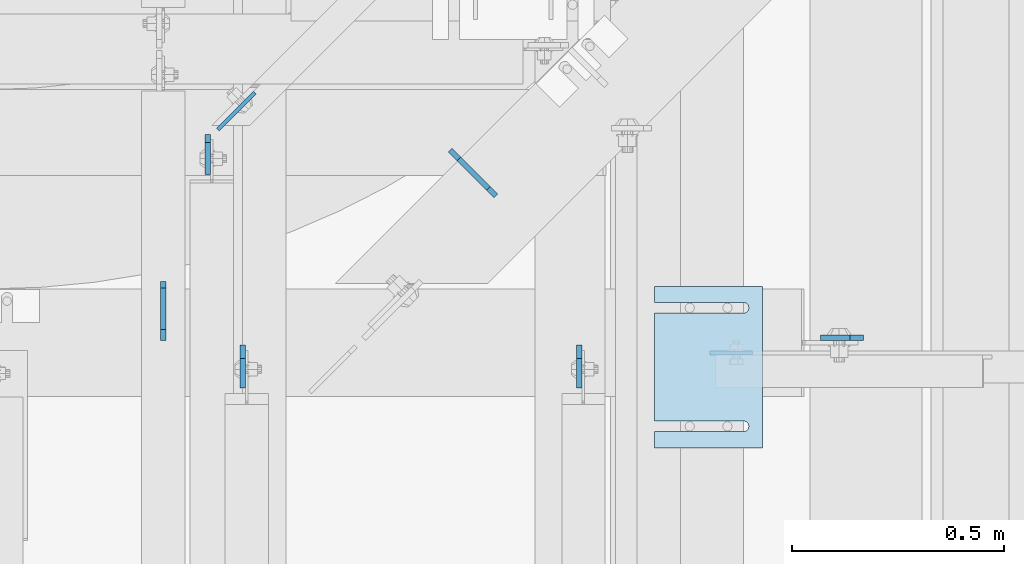
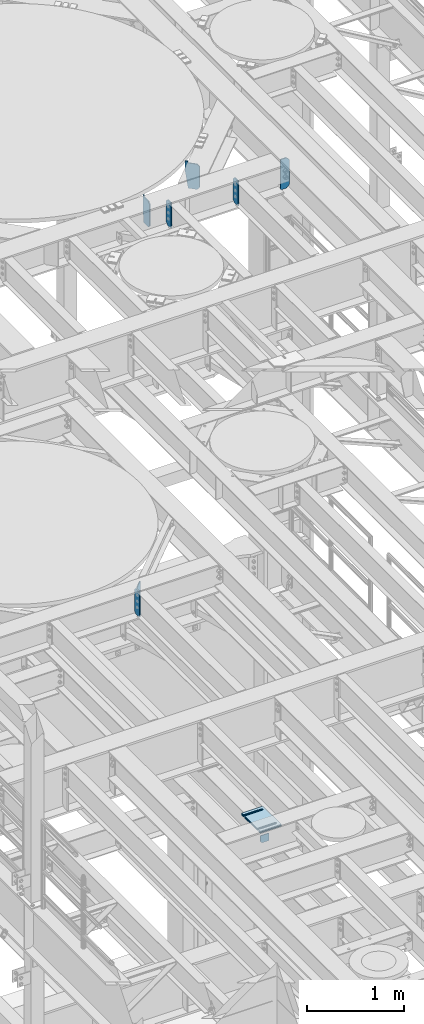
# One storey, part 1738 of 1876: 14 plates, 11 elements without a shape of their own.
"""IFC2X3 building model written with IfcOpenShell, lengths in millimetres."""

from ifc_helpers import new_model, si_unit, frame, origin_with_axes, place, context, subcontext, project, spatial, faceted_brep, material, type_object, element, aggregate, save


model = new_model("IFC2X3")

# Units and contexts
model_context = context("Model", 3, precision=1e-05, world=origin_with_axes())
body_context = subcontext(model_context, "Body", "Model", "MODEL_VIEW")
ifc_project = project(units=[si_unit("LENGTHUNIT", "METRE", prefix="MILLI"), si_unit("AREAUNIT", "SQUARE_METRE"), si_unit("VOLUMEUNIT", "CUBIC_METRE"), si_unit("MASSUNIT", "GRAM", prefix="KILO"), si_unit("TIMEUNIT", "SECOND"), si_unit("PLANEANGLEUNIT", "RADIAN"), si_unit("SOLIDANGLEUNIT", "STERADIAN"), si_unit("THERMODYNAMICTEMPERATUREUNIT", "DEGREE_CELSIUS"), si_unit("LUMINOUSINTENSITYUNIT", "LUMEN")], contexts=[model_context])

# Site, building, storey
site_placement = place(None, origin_with_axes())
site = spatial("IfcSite", under=ifc_project, at=site_placement, CompositionType="ELEMENT")
building_placement = place(site_placement, origin_with_axes())
building = spatial("IfcBuilding", under=site, at=building_placement, Name="Undefined", CompositionType="ELEMENT")
storey_placement = place(building_placement, origin_with_axes())
storey = spatial("IfcBuildingStorey", under=building, at=storey_placement, Name="Undefined", CompositionType="ELEMENT", Elevation=0.0)

# Assembly, plate
assembly_1_placement = place(storey_placement, origin_with_axes())
assembly_1 = element("IfcElementAssembly", 1, at=assembly_1_placement, inside=storey, Name="BEAM", AssemblyPlace="NOTDEFINED", PredefinedType="RIGID_FRAME")
ifc_material = material(Name="STEEL/A36")
plate_type_1 = type_object("IfcPlateType", PredefinedType="NOTDEFINED")
plate_1_placement = place(assembly_1_placement, frame((4883.15000022323, 9399.24522705379, 4921.97603368486), z_axis=(1.0, 0.0, 0.0), x_axis=(0.0, 0.0, -1.0)))
plate_1 = element("IfcPlate", 2, at=plate_1_placement, type_object=plate_type_1, material=ifc_material, Name="PLATE", context=body_context, shape_type="Brep", body=[
    faceted_brep([(0.0, -4.76249999999982, 0.0), (0.0, -4.76250000000073, 100.270820617676), (0.0, 4.76250000000073, 100.270820617676), (0.0, 4.76249999999982, 0.0), (92.8010330200195, -4.76250000000073, 100.270820617676), (92.8010330200195, 4.76250000000073, 100.270820617676), (92.8010330200195, -4.76250000000073, 19.0499992370605), (92.8010330200195, 4.76250000000073, 19.0499992370605), (73.751033782959, -4.76250000000073, 0.0), (73.751033782959, 4.76250000000073, 0.0)], [[[0, 1, 2, 3]], [[1, 4, 5, 2]], [[4, 6, 7, 5]], [[6, 8, 9, 7]], [[8, 0, 3, 9]], [[5, 7, 9, 3, 2]], [[8, 6, 4, 1, 0]]]),
])
aggregate(assembly_1, [plate_1])

assembly_2_placement = place(storey_placement, origin_with_axes())
assembly_2 = element("IfcElementAssembly", 3, at=assembly_2_placement, inside=storey, Name="BEAM", AssemblyPlace="NOTDEFINED", PredefinedType="RIGID_FRAME")
plate_type_2 = type_object("IfcPlateType", PredefinedType="NOTDEFINED")
plate_2_placement = place(assembly_2_placement, frame((3698.87499990463, 9914.73125, 7821.6125), z_axis=(0.0, 0.0, 1.0), x_axis=(0.0, -1.0, 0.0)))
plate_2 = element("IfcPlate", 4, at=plate_2_placement, type_object=plate_type_2, material=ifc_material, Name="PLATE", context=body_context, shape_type="Brep", body=[
    faceted_brep([(0.0, -6.35000000000196, 19.0499992370605), (-9.09494701772928e-13, -6.34999999999764, 296.862506866455), (1.81898940354586e-12, 6.34999999999786, 296.862506866455), (0.0, 6.35000000000105, 19.0499992370605), (19.0499992370587, -6.34999999999604, 315.912506103516), (19.0499992370624, 6.34999999999945, 315.912506103516), (95.25, -6.35000000000036, 315.912506103516), (95.25, 6.35000000000036, 315.912506103516), (95.25, -6.35000000000036, 0.0), (95.25, 6.35000000000036, 0.0), (19.0499992370642, -6.35000000000105, 0.0), (19.0499992370633, 6.35000000000105, 0.0)], [[[0, 1, 2, 3]], [[1, 4, 5, 2]], [[4, 6, 7, 5]], [[6, 8, 9, 7]], [[8, 10, 11, 9]], [[10, 0, 3, 11]], [[5, 7, 9, 11, 3, 2]], [[10, 8, 6, 4, 1, 0]]]),
])

# Assembly, plates
assembly_3_placement = place(storey_placement, origin_with_axes())
assembly_3 = element("IfcElementAssembly", 5, at=assembly_3_placement, inside=storey, Name="BEAM", AssemblyPlace="NOTDEFINED", PredefinedType="RIGID_FRAME")
plate_type_3 = type_object("IfcPlateType", PredefinedType="NOTDEFINED")
plate_3_placement = place(assembly_3_placement, frame((4575.17499990465, 9417.84375, 12974.6375), z_axis=(0.0, 0.0, 1.0), x_axis=(0.0, -1.0, 0.0)))
plate_3 = element("IfcPlate", 6, at=plate_3_placement, type_object=plate_type_3, material=ifc_material, Name="PLATE", context=body_context, shape_type="Brep", body=[
    faceted_brep([(0.0, -6.34999999999991, 31.75), (-1.81898940354586e-12, -6.34999999999991, 284.162506103516), (1.81898940354586e-12, 6.35000000000173, 284.162506103516), (0.0, 6.34999999999991, 31.75), (31.7499999999927, -6.34999999999991, 315.912506103516), (31.7499999999982, 6.35000000000309, 315.912506103516), (101.599998474121, -6.35000000000036, 315.912506103516), (101.599998474121, 6.35000000000036, 315.912506103516), (101.599998474121, -6.35000000000036, 0.0), (101.599998474121, 6.35000000000036, 0.0), (31.75, -6.34999999999991, 0.0), (31.75, 6.34999999999991, 0.0)], [[[0, 1, 2, 3]], [[1, 4, 5, 2]], [[4, 6, 7, 5]], [[6, 8, 9, 7]], [[8, 10, 11, 9]], [[10, 0, 3, 11]], [[5, 7, 9, 11, 3, 2]], [[10, 8, 6, 4, 1, 0]]]),
])
plate_4_placement = place(assembly_3_placement, frame((3781.42499990463, 9417.84375, 12974.6375), z_axis=(0.0, 0.0, 1.0), x_axis=(0.0, -1.0, 0.0)))
plate_4 = element("IfcPlate", 7, at=plate_4_placement, type_object=plate_type_3, material=ifc_material, Name="PLATE", context=body_context, shape_type="Brep", body=[
    faceted_brep([(0.0, -6.34999999999991, 31.75), (-1.81898940354586e-12, -6.34999999999991, 284.162506103516), (1.81898940354586e-12, 6.35000000000173, 284.162506103516), (0.0, 6.34999999999991, 31.75), (31.7499999999927, -6.34999999999991, 315.912506103516), (31.7499999999982, 6.35000000000309, 315.912506103516), (101.599998474121, -6.35000000000036, 315.912506103516), (101.599998474121, 6.35000000000036, 315.912506103516), (101.599998474121, -6.35000000000036, 0.0), (101.599998474121, 6.35000000000036, 0.0), (31.75, -6.34999999999991, 0.0), (31.75, 6.34999999999991, 0.0)], [[[0, 1, 2, 3]], [[1, 4, 5, 2]], [[4, 6, 7, 5]], [[6, 8, 9, 7]], [[8, 10, 11, 9]], [[10, 0, 3, 11]], [[5, 7, 9, 11, 3, 2]], [[10, 8, 6, 4, 1, 0]]]),
])

# Assembly, plate
assembly_4_placement = place(storey_placement, origin_with_axes())
assembly_4 = element("IfcElementAssembly", 8, at=assembly_4_placement, inside=storey, Name="BEAM", AssemblyPlace="NOTDEFINED", PredefinedType="RIGID_FRAME")
plate_5_placement = place(assembly_4_placement, frame((5245.09999844433, 9435.30625009537, 12907.9625), z_axis=(0.0, 0.0, 1.0), x_axis=(-1.0, 0.0, 0.0)))
plate_5 = element("IfcPlate", 9, at=plate_5_placement, type_object=plate_type_3, material=ifc_material, Name="PLATE", context=body_context, shape_type="Brep", body=[
    faceted_brep([(0.0, -6.34999999999991, 31.75), (9.09494701772928e-13, -6.35000000000036, 347.662506103516), (-9.09494701772928e-13, 6.35000000000036, 347.662506103516), (0.0, 6.34999999999991, 31.75), (31.7500000000055, -6.35000000000036, 379.412506103516), (31.7500000000055, 6.35000000000036, 379.412506103516), (101.599998474121, -6.35000000000036, 379.412506103516), (101.599998474121, 6.35000000000036, 379.412506103516), (101.599998474121, -6.35000000000036, 0.0), (101.599998474121, 6.35000000000036, 0.0), (31.75, -6.34999999999991, 0.0), (31.75, 6.34999999999991, 0.0)], [[[0, 1, 2, 3]], [[1, 4, 5, 2]], [[4, 6, 7, 5]], [[6, 8, 9, 7]], [[8, 10, 11, 9]], [[10, 0, 3, 11]], [[5, 7, 9, 11, 3, 2]], [[10, 8, 6, 4, 1, 0]]]),
])
aggregate(assembly_4, [plate_5])

assembly_5_placement = place(storey_placement, origin_with_axes())
assembly_5 = element("IfcElementAssembly", 10, at=assembly_5_placement, inside=storey, Name="SHIM PLATE", AssemblyPlace="NOTDEFINED", PredefinedType="RIGID_FRAME")
plate_type_4 = type_object("IfcPlateType", PredefinedType="NOTDEFINED")
plate_6_placement = place(assembly_5_placement, frame((5006.97497877827, 9556.41075440966, 5154.6115), z_axis=(0.0, -1.0, 0.0), x_axis=(-1.0, 0.0, 0.0)))
plate_6 = element("IfcPlate", 11, at=plate_6_placement, type_object=plate_type_4, material=ifc_material, Name="SHIM PLATE", context=body_context, shape_type="Brep", body=[
    faceted_brep([(253.999554443153, -1.58749999999964, 38.1033648203102), (253.999554443153, 1.58749999999964, 38.1033648203102), (44.4515180349081, 1.58749999999964, 38.1033599194243), (44.4515180349081, -1.58749999999964, 38.1033599194243), (38.1012989900955, 1.58749999999964, 39.8049650059338), (38.1012989900955, -1.58749999999964, 39.8049650059338), (33.4527432566947, 1.58749999999964, 44.4538004924843), (33.4527432566947, -1.58749999999964, 44.4538004924843), (31.7515203221346, 1.58749999999964, 50.8041219264323), (31.7515203221346, -1.58749999999964, 50.8041219264323), (33.4535054350827, 1.58749999999964, 57.1542391271496), (33.4535054350827, -1.58749999999964, 57.1542391271496), (38.102619106583, 1.58749999999964, 61.8025166422085), (38.102619106583, -1.58749999999964, 61.8025166422085), (44.4530423390142, 1.58749999999964, 63.5033595381092), (44.4530423390142, -1.58749999999964, 63.5033595381092), (253.999552185923, -1.58749999999964, 63.5033587167945), (253.999552408692, 1.58749999999964, 63.5033587167945), (253.999542236328, -1.58750000000146, 6.16182660451159e-11), (9.09494701772928e-13, -1.58750000000146, 4.54747350886464e-13), (9.09494701772928e-13, 1.58750000000146, 4.54747350886464e-13), (253.999542236328, 1.58750000000146, 6.16182660451159e-11), (-1.83084230229724e-05, -1.58749999999964, 381.006103515625), (-1.83084230229724e-05, 1.58749999999964, 381.006103515625), (253.999526977692, -1.58749999999964, 381.006103515754), (253.999526977692, 1.58749999999964, 381.006103515754), (254.003036796345, -1.58749999999964, 342.901806793585), (253.999530029731, 1.58749999999964, 342.901806793307), (44.4530337445867, -1.58749999999964, 342.901796525332), (44.4530337445867, 1.58749999999964, 342.901796525332), (38.1026104900466, -1.58749999999964, 341.200953711996), (38.1026104900466, 1.58749999999964, 341.200953711996), (33.4534967581139, -1.58749999999964, 336.552676257383), (33.4534967581139, 1.58749999999964, 336.552676257383), (31.7515115626111, -1.58749999999964, 330.202559078798), (31.7515115626111, 1.58749999999964, 330.202559078798), (33.4527344146145, -1.58749999999964, 323.852237622745), (33.4527344146145, 1.58749999999964, 323.852237622745), (38.1012900875803, -1.58749999999964, 319.203402075782), (38.1012900875803, 1.58749999999964, 319.203402075782), (44.4515091102685, -1.58749999999964, 317.501796906747), (44.4515091102685, 1.58749999999964, 317.501796906747), (253.999532064192, -1.58749999999964, 317.501812896822), (253.999532064192, 1.58749999999964, 317.501812896822)], [[[0, 1, 2, 3]], [[3, 2, 4, 5]], [[5, 4, 6, 7]], [[7, 6, 8, 9]], [[9, 8, 10, 11]], [[11, 10, 12, 13]], [[13, 12, 14, 15]], [[16, 15, 14, 17]], [[18, 19, 20, 21]], [[19, 22, 23, 20]], [[22, 24, 25, 23]], [[25, 24, 26, 27]], [[26, 28, 29, 27]], [[30, 31, 29, 28]], [[32, 33, 31, 30]], [[34, 35, 33, 32]], [[36, 37, 35, 34]], [[38, 39, 37, 36]], [[40, 41, 39, 38]], [[42, 43, 41, 40]], [[43, 42, 16, 17]], [[12, 10, 8, 6, 4, 2, 1, 21, 20, 23, 25, 27, 29, 31, 33, 35, 37, 39, 41, 43, 17, 14]], [[18, 21, 1, 0]], [[42, 40, 38, 36, 34, 32, 30, 28, 26, 24, 22, 19, 18, 0, 3, 5, 7, 9, 11, 13, 15, 16]]]),
])
aggregate(assembly_5, [plate_6])

assembly_6_placement = place(storey_placement, origin_with_axes())
assembly_6 = element("IfcElementAssembly", 12, at=assembly_6_placement, inside=storey, Name="SHIM PLATE", AssemblyPlace="NOTDEFINED", PredefinedType="RIGID_FRAME")
plate_7_placement = place(assembly_6_placement, frame((5006.97497877827, 9556.41075440966, 5151.4365), z_axis=(0.0, -1.0, 0.0), x_axis=(-1.0, 0.0, 0.0)))
plate_7 = element("IfcPlate", 13, at=plate_7_placement, type_object=plate_type_4, material=ifc_material, Name="SHIM PLATE", context=body_context, shape_type="Brep", body=[
    faceted_brep([(253.999554443153, -1.58749999999964, 38.1033648203102), (253.999554443153, 1.58749999999964, 38.1033648203102), (44.4515180349081, 1.58749999999964, 38.1033599194243), (44.4515180349081, -1.58749999999964, 38.1033599194243), (38.1012989900955, 1.58749999999964, 39.8049650059338), (38.1012989900955, -1.58749999999964, 39.8049650059338), (33.4527432566947, 1.58749999999964, 44.4538004924843), (33.4527432566947, -1.58749999999964, 44.4538004924843), (31.7515203221346, 1.58749999999964, 50.8041219264323), (31.7515203221346, -1.58749999999964, 50.8041219264323), (33.4535054350827, 1.58749999999964, 57.1542391271496), (33.4535054350827, -1.58749999999964, 57.1542391271496), (38.102619106583, 1.58749999999964, 61.8025166422085), (38.102619106583, -1.58749999999964, 61.8025166422085), (44.4530423390142, 1.58749999999964, 63.5033595381092), (44.4530423390142, -1.58749999999964, 63.5033595381092), (253.999552185923, -1.58749999999964, 63.5033587167945), (253.999552408692, 1.58749999999964, 63.5033587167945), (253.999542236328, -1.58750000000146, 6.16182660451159e-11), (9.09494701772928e-13, -1.58750000000146, 4.54747350886464e-13), (9.09494701772928e-13, 1.58750000000146, 4.54747350886464e-13), (253.999542236328, 1.58750000000146, 6.16182660451159e-11), (-1.83084230229724e-05, -1.58749999999964, 381.006103515625), (-1.83084230229724e-05, 1.58749999999964, 381.006103515625), (253.999526977692, -1.58749999999964, 381.006103515754), (253.999526977692, 1.58749999999964, 381.006103515754), (254.003036796345, -1.58749999999964, 342.901806793585), (253.999530029731, 1.58749999999964, 342.901806793307), (44.4530337445867, -1.58749999999964, 342.901796525332), (44.4530337445867, 1.58749999999964, 342.901796525332), (38.1026104900466, -1.58749999999964, 341.200953711996), (38.1026104900466, 1.58749999999964, 341.200953711996), (33.4534967581139, -1.58749999999964, 336.552676257383), (33.4534967581139, 1.58749999999964, 336.552676257383), (31.7515115626111, -1.58749999999964, 330.202559078798), (31.7515115626111, 1.58749999999964, 330.202559078798), (33.4527344146145, -1.58749999999964, 323.852237622745), (33.4527344146145, 1.58749999999964, 323.852237622745), (38.1012900875803, -1.58749999999964, 319.203402075782), (38.1012900875803, 1.58749999999964, 319.203402075782), (44.4515091102685, -1.58749999999964, 317.501796906747), (44.4515091102685, 1.58749999999964, 317.501796906747), (253.999532064192, -1.58749999999964, 317.501812896822), (253.999532064192, 1.58749999999964, 317.501812896822)], [[[0, 1, 2, 3]], [[3, 2, 4, 5]], [[5, 4, 6, 7]], [[7, 6, 8, 9]], [[9, 8, 10, 11]], [[11, 10, 12, 13]], [[13, 12, 14, 15]], [[16, 15, 14, 17]], [[18, 19, 20, 21]], [[19, 22, 23, 20]], [[22, 24, 25, 23]], [[25, 24, 26, 27]], [[26, 28, 29, 27]], [[30, 31, 29, 28]], [[32, 33, 31, 30]], [[34, 35, 33, 32]], [[36, 37, 35, 34]], [[38, 39, 37, 36]], [[40, 41, 39, 38]], [[42, 43, 41, 40]], [[43, 42, 16, 17]], [[12, 10, 8, 6, 4, 2, 1, 21, 20, 23, 25, 27, 29, 31, 33, 35, 37, 39, 41, 43, 17, 14]], [[18, 21, 1, 0]], [[42, 40, 38, 36, 34, 32, 30, 28, 26, 24, 22, 19, 18, 0, 3, 5, 7, 9, 11, 13, 15, 16]]]),
])
aggregate(assembly_6, [plate_7])

assembly_7_placement = place(storey_placement, origin_with_axes())
assembly_7 = element("IfcElementAssembly", 14, at=assembly_7_placement, inside=storey, Name="SHIM PLATE", AssemblyPlace="NOTDEFINED", PredefinedType="RIGID_FRAME")
plate_type_5 = type_object("IfcPlateType", PredefinedType="NOTDEFINED")
plate_8_placement = place(assembly_7_placement, frame((5006.97497877827, 9556.41075440966, 5156.9925), z_axis=(0.0, -1.0, 0.0), x_axis=(-1.0, 0.0, 0.0)))
plate_8 = element("IfcPlate", 15, at=plate_8_placement, type_object=plate_type_5, material=ifc_material, Name="SHIM PLATE", context=body_context, shape_type="Brep", body=[
    faceted_brep([(253.999554443153, -0.793499999999767, 38.1033648203102), (253.999554443153, 0.793499999999767, 38.1033648203102), (44.4515180349072, 0.793499999999767, 38.1033599194234), (44.4515180349072, -0.793499999999767, 38.1033599194234), (38.1012989900946, 0.793499999999767, 39.8049650059329), (38.1012989900946, -0.793499999999767, 39.8049650059329), (33.4527432566938, 0.793499999999767, 44.4538004924834), (33.4527432566938, -0.793499999999767, 44.4538004924834), (31.7515203221337, 0.793499999999767, 50.8041219264314), (31.7515203221337, -0.793499999999767, 50.8041219264314), (33.4535054350818, 0.793499999999767, 57.1542391271487), (33.4535054350818, -0.793499999999767, 57.1542391271487), (38.1026191065821, 0.793499999999767, 61.8025166422076), (38.1026191065821, -0.793499999999767, 61.8025166422076), (44.4530423390133, 0.793499999999767, 63.5033595381083), (44.4530423390133, -0.793499999999767, 63.5033595381083), (253.999552185923, -0.793499999999767, 63.5033587167945), (253.999552408692, 0.793499999999767, 63.5033587167945), (253.999542236328, -0.793499999999767, 6.16182660451159e-11), (9.09494701772928e-13, -0.793499999999767, 0.0), (9.09494701772928e-13, 0.793499999999767, 0.0), (253.999542236328, 0.793499999999767, 6.16182660451159e-11), (-1.83080774149857e-05, -0.793499999999767, 381.006103515625), (-1.83080774149857e-05, 0.793499999999767, 381.006103515625), (253.999526977692, -0.793499999999767, 381.006103515754), (253.999526977692, 0.793499999999767, 381.006103515754), (254.003036796345, -0.793499999999767, 342.901806793585), (253.999530029731, 0.793499999999767, 342.901806793307), (44.4530337445867, -0.793499999999767, 342.901796525332), (44.4530337445867, 0.793499999999767, 342.901796525332), (38.1026104900466, -0.793499999999767, 341.200953711996), (38.1026104900466, 0.793499999999767, 341.200953711996), (33.4534967581139, -0.793499999999767, 336.552676257383), (33.4534967581139, 0.793499999999767, 336.552676257383), (31.7515115626111, -0.793499999999767, 330.202559078798), (31.7515115626111, 0.793499999999767, 330.202559078798), (33.4527344146145, -0.793499999999767, 323.852237622745), (33.4527344146145, 0.793499999999767, 323.852237622745), (38.1012900875803, -0.793499999999767, 319.203402075782), (38.1012900875803, 0.793499999999767, 319.203402075782), (44.4515091102685, -0.793499999999767, 317.501796906747), (44.4515091102685, 0.793499999999767, 317.501796906747), (253.999532064192, -0.793499999999767, 317.501812896822), (253.999532064192, 0.793499999999767, 317.501812896822)], [[[0, 1, 2, 3]], [[3, 2, 4, 5]], [[5, 4, 6, 7]], [[7, 6, 8, 9]], [[9, 8, 10, 11]], [[11, 10, 12, 13]], [[13, 12, 14, 15]], [[16, 15, 14, 17]], [[18, 19, 20, 21]], [[19, 22, 23, 20]], [[22, 24, 25, 23]], [[25, 24, 26, 27]], [[26, 28, 29, 27]], [[30, 31, 29, 28]], [[32, 33, 31, 30]], [[34, 35, 33, 32]], [[36, 37, 35, 34]], [[38, 39, 37, 36]], [[40, 41, 39, 38]], [[42, 43, 41, 40]], [[43, 42, 16, 17]], [[12, 10, 8, 6, 4, 2, 1, 21, 20, 23, 25, 27, 29, 31, 33, 35, 37, 39, 41, 43, 17, 14]], [[18, 21, 1, 0]], [[42, 40, 38, 36, 34, 32, 30, 28, 26, 24, 22, 19, 18, 0, 3, 5, 7, 9, 11, 13, 15, 16]]]),
])
aggregate(assembly_7, [plate_8])

assembly_8_placement = place(storey_placement, origin_with_axes())
assembly_8 = element("IfcElementAssembly", 16, at=assembly_8_placement, inside=storey, Name="SHIM PLATE", AssemblyPlace="NOTDEFINED", PredefinedType="RIGID_FRAME")
plate_type_6 = type_object("IfcPlateType", PredefinedType="NOTDEFINED")
plate_9_placement = place(assembly_8_placement, frame((5006.97497877827, 9556.41075440966, 5147.468), z_axis=(0.0, -1.0, 0.0), x_axis=(-1.0, 0.0, 0.0)))
plate_9 = element("IfcPlate", 17, at=plate_9_placement, type_object=plate_type_6, material=ifc_material, Name="SHIM PLATE", context=body_context, shape_type="Brep", body=[
    faceted_brep([(253.999554443153, -2.38100000000031, 38.1033648203102), (253.999554443153, 2.38100000000031, 38.1033648203102), (44.4515180349081, 2.38100000000031, 38.1033599194243), (44.4515180349081, -2.38100000000031, 38.1033599194243), (38.1012989900955, 2.38100000000031, 39.8049650059338), (38.1012989900955, -2.38100000000031, 39.8049650059338), (33.4527432566947, 2.38100000000031, 44.4538004924843), (33.4527432566947, -2.38100000000031, 44.4538004924843), (31.7515203221346, 2.38100000000031, 50.8041219264323), (31.7515203221346, -2.38100000000031, 50.8041219264323), (33.4535054350827, 2.38100000000031, 57.1542391271496), (33.4535054350827, -2.38100000000031, 57.1542391271496), (38.102619106583, 2.38100000000031, 61.8025166422085), (38.102619106583, -2.38100000000031, 61.8025166422085), (44.4530423390142, 2.38100000000031, 63.5033595381092), (44.4530423390142, -2.38100000000031, 63.5033595381092), (253.999552185923, -2.38100000000031, 63.5033587167945), (253.999552408692, 2.38100000000031, 63.5033587167945), (253.999542236328, -2.38100000000122, 6.16182660451159e-11), (0.0, -2.38100000000122, 4.54747350886464e-13), (0.0, 2.38100000000122, 4.54747350886464e-13), (253.999542236328, 2.38100000000122, 6.16182660451159e-11), (-1.83087686309591e-05, -2.38100000000031, 381.006103515625), (-1.83087686309591e-05, 2.38100000000031, 381.006103515625), (253.999526977692, -2.38100000000031, 381.006103515754), (253.999526977692, 2.38100000000031, 381.006103515754), (254.003036796345, -2.38100000000031, 342.901806793585), (253.999530029731, 2.38100000000031, 342.901806793307), (44.4530337445867, -2.38100000000031, 342.901796525332), (44.4530337445867, 2.38100000000031, 342.901796525332), (38.1026104900466, -2.38100000000031, 341.200953711996), (38.1026104900466, 2.38100000000031, 341.200953711996), (33.4534967581139, -2.38100000000031, 336.552676257383), (33.4534967581139, 2.38100000000031, 336.552676257383), (31.7515115626111, -2.38100000000031, 330.202559078798), (31.7515115626111, 2.38100000000031, 330.202559078798), (33.4527344146145, -2.38100000000031, 323.852237622745), (33.4527344146145, 2.38100000000031, 323.852237622745), (38.1012900875803, -2.38100000000031, 319.203402075782), (38.1012900875803, 2.38100000000031, 319.203402075782), (44.4515091102685, -2.38100000000031, 317.501796906747), (44.4515091102685, 2.38100000000031, 317.501796906747), (253.999532064192, -2.38100000000031, 317.501812896822), (253.999532064192, 2.38100000000031, 317.501812896822)], [[[0, 1, 2, 3]], [[3, 2, 4, 5]], [[5, 4, 6, 7]], [[7, 6, 8, 9]], [[9, 8, 10, 11]], [[11, 10, 12, 13]], [[13, 12, 14, 15]], [[16, 15, 14, 17]], [[18, 19, 20, 21]], [[19, 22, 23, 20]], [[22, 24, 25, 23]], [[25, 24, 26, 27]], [[26, 28, 29, 27]], [[30, 31, 29, 28]], [[32, 33, 31, 30]], [[34, 35, 33, 32]], [[36, 37, 35, 34]], [[38, 39, 37, 36]], [[40, 41, 39, 38]], [[42, 43, 41, 40]], [[43, 42, 16, 17]], [[12, 10, 8, 6, 4, 2, 1, 21, 20, 23, 25, 27, 29, 31, 33, 35, 37, 39, 41, 43, 17, 14]], [[18, 21, 1, 0]], [[42, 40, 38, 36, 34, 32, 30, 28, 26, 24, 22, 19, 18, 0, 3, 5, 7, 9, 11, 13, 15, 16]]]),
])
aggregate(assembly_8, [plate_9])

assembly_9_placement = place(storey_placement, origin_with_axes())
assembly_9 = element("IfcElementAssembly", 18, at=assembly_9_placement, inside=storey, Name="SHIM PLATE", AssemblyPlace="NOTDEFINED", PredefinedType="RIGID_FRAME")
plate_10_placement = place(assembly_9_placement, frame((5006.97497877827, 9556.41075440966, 5142.706), z_axis=(0.0, -1.0, 0.0), x_axis=(-1.0, 0.0, 0.0)))
plate_10 = element("IfcPlate", 19, at=plate_10_placement, type_object=plate_type_6, material=ifc_material, Name="SHIM PLATE", context=body_context, shape_type="Brep", body=[
    faceted_brep([(253.999554443153, -2.38100000000031, 38.1033648203102), (253.999554443153, 2.38100000000031, 38.1033648203102), (44.4515180349081, 2.38100000000031, 38.1033599194243), (44.4515180349081, -2.38100000000031, 38.1033599194243), (38.1012989900955, 2.38100000000031, 39.8049650059338), (38.1012989900955, -2.38100000000031, 39.8049650059338), (33.4527432566947, 2.38100000000031, 44.4538004924843), (33.4527432566947, -2.38100000000031, 44.4538004924843), (31.7515203221346, 2.38100000000031, 50.8041219264323), (31.7515203221346, -2.38100000000031, 50.8041219264323), (33.4535054350827, 2.38100000000031, 57.1542391271496), (33.4535054350827, -2.38100000000031, 57.1542391271496), (38.102619106583, 2.38100000000031, 61.8025166422085), (38.102619106583, -2.38100000000031, 61.8025166422085), (44.4530423390142, 2.38100000000031, 63.5033595381092), (44.4530423390142, -2.38100000000031, 63.5033595381092), (253.999552185923, -2.38100000000031, 63.5033587167945), (253.999552408692, 2.38100000000031, 63.5033587167945), (253.999542236328, -2.38100000000122, 6.16182660451159e-11), (0.0, -2.38100000000122, 4.54747350886464e-13), (0.0, 2.38100000000122, 4.54747350886464e-13), (253.999542236328, 2.38100000000122, 6.16182660451159e-11), (-1.83087686309591e-05, -2.38100000000031, 381.006103515625), (-1.83087686309591e-05, 2.38100000000031, 381.006103515625), (253.999526977692, -2.38100000000031, 381.006103515754), (253.999526977692, 2.38100000000031, 381.006103515754), (254.003036796345, -2.38100000000031, 342.901806793585), (253.999530029731, 2.38100000000031, 342.901806793307), (44.4530337445867, -2.38100000000031, 342.901796525332), (44.4530337445867, 2.38100000000031, 342.901796525332), (38.1026104900466, -2.38100000000031, 341.200953711996), (38.1026104900466, 2.38100000000031, 341.200953711996), (33.4534967581139, -2.38100000000031, 336.552676257383), (33.4534967581139, 2.38100000000031, 336.552676257383), (31.7515115626111, -2.38100000000031, 330.202559078798), (31.7515115626111, 2.38100000000031, 330.202559078798), (33.4527344146145, -2.38100000000031, 323.852237622745), (33.4527344146145, 2.38100000000031, 323.852237622745), (38.1012900875803, -2.38100000000031, 319.203402075782), (38.1012900875803, 2.38100000000031, 319.203402075782), (44.4515091102685, -2.38100000000031, 317.501796906747), (44.4515091102685, 2.38100000000031, 317.501796906747), (253.999532064192, -2.38100000000031, 317.501812896822), (253.999532064192, 2.38100000000031, 317.501812896822)], [[[0, 1, 2, 3]], [[3, 2, 4, 5]], [[5, 4, 6, 7]], [[7, 6, 8, 9]], [[9, 8, 10, 11]], [[11, 10, 12, 13]], [[13, 12, 14, 15]], [[16, 15, 14, 17]], [[18, 19, 20, 21]], [[19, 22, 23, 20]], [[22, 24, 25, 23]], [[25, 24, 26, 27]], [[26, 28, 29, 27]], [[30, 31, 29, 28]], [[32, 33, 31, 30]], [[34, 35, 33, 32]], [[36, 37, 35, 34]], [[38, 39, 37, 36]], [[40, 41, 39, 38]], [[42, 43, 41, 40]], [[43, 42, 16, 17]], [[12, 10, 8, 6, 4, 2, 1, 21, 20, 23, 25, 27, 29, 31, 33, 35, 37, 39, 41, 43, 17, 14]], [[18, 21, 1, 0]], [[42, 40, 38, 36, 34, 32, 30, 28, 26, 24, 22, 19, 18, 0, 3, 5, 7, 9, 11, 13, 15, 16]]]),
])
aggregate(assembly_9, [plate_10])

assembly_10_placement = place(storey_placement, origin_with_axes())
assembly_10 = element("IfcElementAssembly", 20, at=assembly_10_placement, inside=storey, Name="SHIM PLATE", AssemblyPlace="NOTDEFINED", PredefinedType="RIGID_FRAME")
plate_type_7 = type_object("IfcPlateType", PredefinedType="NOTDEFINED")
plate_11_placement = place(assembly_10_placement, frame((5006.97497877827, 9556.41075440966, 5135.5625), z_axis=(0.0, -1.0, 0.0), x_axis=(-1.0, 0.0, 0.0)))
plate_11 = element("IfcPlate", 21, at=plate_11_placement, type_object=plate_type_7, material=ifc_material, Name="SHIM PLATE", context=body_context, shape_type="Brep", body=[
    faceted_brep([(253.999554443153, -4.76249999999982, 38.1033648203102), (253.999554443153, 4.76249999999982, 38.1033648203102), (44.4515180349081, 4.76249999999982, 38.1033599194243), (44.4515180349081, -4.76249999999982, 38.1033599194243), (38.1012989900955, 4.76249999999982, 39.8049650059338), (38.1012989900955, -4.76249999999982, 39.8049650059338), (33.4527432566947, 4.76249999999982, 44.4538004924843), (33.4527432566947, -4.76249999999982, 44.4538004924843), (31.7515203221346, 4.76249999999982, 50.8041219264323), (31.7515203221346, -4.76249999999982, 50.8041219264323), (33.4535054350827, 4.76249999999982, 57.1542391271496), (33.4535054350827, -4.76249999999982, 57.1542391271496), (38.102619106583, 4.76249999999982, 61.8025166422085), (38.102619106583, -4.76249999999982, 61.8025166422085), (44.4530423390142, 4.76249999999982, 63.5033595381092), (44.4530423390142, -4.76249999999982, 63.5033595381092), (253.999552185923, -4.76249999999982, 63.5033587167945), (253.999552408692, 4.76249999999982, 63.5033587167945), (253.999542236328, -4.76250000000073, 6.16182660451159e-11), (0.0, -4.76249999999982, 0.0), (0.0, 4.76249999999982, 0.0), (253.999542236328, 4.76250000000073, 6.16182660451159e-11), (-1.83091142389458e-05, -4.76249999999982, 381.006103515625), (-1.83091142389458e-05, 4.76249999999982, 381.006103515625), (253.999526977692, -4.76249999999982, 381.006103515754), (253.999526977692, 4.76249999999982, 381.006103515754), (254.003036796345, -4.76249999999982, 342.901806793585), (253.999530029731, 4.76249999999982, 342.901806793307), (44.4530337445867, -4.76249999999982, 342.901796525332), (44.4530337445867, 4.76249999999982, 342.901796525332), (38.1026104900466, -4.76249999999982, 341.200953711996), (38.1026104900466, 4.76249999999982, 341.200953711996), (33.4534967581139, -4.76249999999982, 336.552676257383), (33.4534967581139, 4.76249999999982, 336.552676257383), (31.7515115626111, -4.76249999999982, 330.202559078798), (31.7515115626111, 4.76249999999982, 330.202559078798), (33.4527344146145, -4.76249999999982, 323.852237622745), (33.4527344146145, 4.76249999999982, 323.852237622745), (38.1012900875803, -4.76249999999982, 319.203402075782), (38.1012900875803, 4.76249999999982, 319.203402075782), (44.4515091102685, -4.76249999999982, 317.501796906747), (44.4515091102685, 4.76249999999982, 317.501796906747), (253.999532064192, -4.76249999999982, 317.501812896822), (253.999532064192, 4.76249999999982, 317.501812896822)], [[[0, 1, 2, 3]], [[3, 2, 4, 5]], [[5, 4, 6, 7]], [[7, 6, 8, 9]], [[9, 8, 10, 11]], [[11, 10, 12, 13]], [[13, 12, 14, 15]], [[16, 15, 14, 17]], [[18, 19, 20, 21]], [[19, 22, 23, 20]], [[22, 24, 25, 23]], [[25, 24, 26, 27]], [[26, 28, 29, 27]], [[30, 31, 29, 28]], [[32, 33, 31, 30]], [[34, 35, 33, 32]], [[36, 37, 35, 34]], [[38, 39, 37, 36]], [[40, 41, 39, 38]], [[42, 43, 41, 40]], [[43, 42, 16, 17]], [[12, 10, 8, 6, 4, 2, 1, 21, 20, 23, 25, 27, 29, 31, 33, 35, 37, 39, 41, 43, 17, 14]], [[18, 21, 1, 0]], [[42, 40, 38, 36, 34, 32, 30, 28, 26, 24, 22, 19, 18, 0, 3, 5, 7, 9, 11, 13, 15, 16]]]),
])
aggregate(assembly_10, [plate_11])

# Plate
plate_type_8 = type_object("IfcPlateType", PredefinedType="NOTDEFINED")
plate_12_placement = place(assembly_2_placement, frame((3723.18332093052, 9926.03729391698, 8121.65), z_axis=(0.707305809668414, 0.706907696668603, 0.0), x_axis=(0.0, 0.0, -1.0)))
plate_12 = element("IfcPlate", 22, at=plate_12_placement, type_object=plate_type_8, material=ifc_material, Name="PLATE", context=body_context, shape_type="Brep", body=[
    faceted_brep([(0.0, -4.76249999999982, 0.0), (0.0, -4.76250000000147, 122.735206604024), (0.0, 4.7625000000009, 122.735206604024), (0.0, 4.76249999999982, 0.0), (152.399993896484, -4.76250000000147, 122.735206604024), (152.399993896484, 4.7625000000009, 122.735206604024), (152.399993896484, -4.76249999999982, 0.0), (152.399993896484, 4.76249999999982, 0.0)], [[[0, 1, 2, 3]], [[1, 4, 5, 2]], [[4, 6, 7, 5]], [[6, 0, 3, 7]], [[5, 7, 3, 2]], [[6, 4, 1, 0]]]),
])

aggregate(assembly_2, [plate_12, plate_2])

# Assembly, plate
assembly_11_placement = place(storey_placement, origin_with_axes())
assembly_11 = element("IfcElementAssembly", 23, at=assembly_11_placement, inside=storey, Name="BEAM", AssemblyPlace="NOTDEFINED", PredefinedType="RIGID_FRAME")
plate_type_9 = type_object("IfcPlateType", PredefinedType="NOTDEFINED")
plate_13_placement = place(assembly_11_placement, frame((4378.28745907562, 9769.45114762081, 12974.637), z_axis=(-0.707106781186548, 0.707106781186547, 0.0), x_axis=(0.0, 0.0, 1.0)))
plate_13 = element("IfcPlate", 24, at=plate_13_placement, type_object=plate_type_9, material=ifc_material, Name="PLATE", context=body_context, shape_type="Brep", body=[
    faceted_brep([(0.0, -6.35000000000036, 25.4000000000005), (0.0, -6.35000000001855, 120.650001525881), (0.0, 6.34999999998035, 120.650001525879), (0.0, 6.35000000000036, 25.4000000000005), (207.962997436523, -6.35000000002401, 152.399993896486), (207.962997436523, 6.34999999997581, 152.399993896484), (334.963012695312, -6.35000000002401, 152.399993896486), (334.963012695312, 6.34999999997581, 152.399993896484), (334.963012695312, -6.35000000001946, 123.030746459965), (334.963012695312, 6.34999999998035, 123.030746459961), (315.912994384766, -6.35000000001946, 123.030746459965), (315.912994384766, 6.34999999998035, 123.030746459961), (315.912994384766, -6.35000000000491, 25.3999996183684), (315.912994384766, 6.34999999999582, 25.3999996183666), (290.512994766235, -6.34999999999945, -1.4915713109076e-10), (290.512994766235, 6.35000000000036, -1.52795109897852e-10), (25.3999996185303, -6.34999999999991, 0.0), (25.3999996185303, 6.34999999999991, 0.0)], [[[0, 1, 2, 3]], [[1, 4, 5, 2]], [[4, 6, 7, 5]], [[6, 8, 9, 7]], [[8, 10, 11, 9]], [[10, 12, 13, 11]], [[12, 14, 15, 13]], [[14, 16, 17, 15]], [[16, 0, 3, 17]], [[5, 7, 9, 11, 13, 15, 17, 3, 2]], [[16, 14, 12, 10, 8, 6, 4, 1, 0]]]),
])
aggregate(assembly_11, [plate_13])

# Plate
plate_type_10 = type_object("IfcPlateType", PredefinedType="NOTDEFINED")
plate_14_placement = place(assembly_3_placement, frame((3594.1, 9550.40050201416, 12973.05), z_axis=(0.0, 0.0, 1.0), x_axis=(0.0, -1.0, 0.0)))
plate_14 = element("IfcPlate", 25, at=plate_14_placement, type_object=plate_type_10, material=ifc_material, Name="PLATE", context=body_context, shape_type="Brep", body=[
    faceted_brep([(0.0, -6.35000000000036, 0.0), (-17.2371788024902, -6.34999999999991, 209.549987792969), (-17.2371788024902, 6.34999999999991, 209.549987792969), (0.0, 6.35000000000036, 0.0), (-17.2371788024902, -6.34999999999991, 336.549987792969), (-17.2371788024902, 6.34999999999991, 336.549987792969), (-1.58699798583984, -6.34999999999991, 336.549987792969), (-1.58699798583984, 6.34999999999991, 336.549987792969), (-1.58749866485596, -6.34999999999991, 317.499969482422), (-1.58749866485596, 6.34999999999991, 317.499969482422), (96.0442523956299, -6.34999999999991, 317.499993699623), (96.0442523956299, 6.34999999999991, 317.499993699623), (121.44425201416, -6.34999999999991, 292.10000038147), (121.44425201416, 6.34999999999991, 292.10000038147), (121.44425201416, -6.34999999999991, 25.3999996185303), (121.44425201416, 6.34999999999991, 25.3999996185303), (96.0442523956299, -6.34999999999991, 0.0), (96.0442523956299, 6.34999999999991, 0.0)], [[[0, 1, 2, 3]], [[1, 4, 5, 2]], [[4, 6, 7, 5]], [[6, 8, 9, 7]], [[8, 10, 11, 9]], [[10, 12, 13, 11]], [[12, 14, 15, 13]], [[14, 16, 17, 15]], [[16, 0, 3, 17]], [[5, 7, 9, 11, 13, 15, 17, 3, 2]], [[16, 14, 12, 10, 8, 6, 4, 1, 0]]]),
])

aggregate(assembly_3, [plate_14, plate_3, plate_4])

save(model, "model.ifc")
